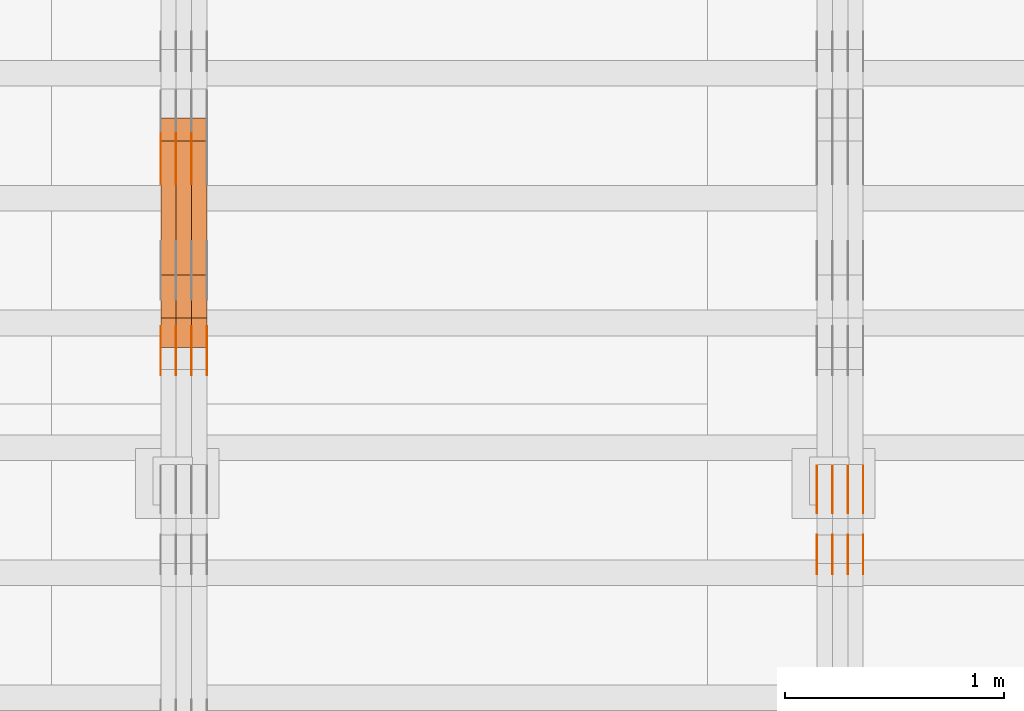
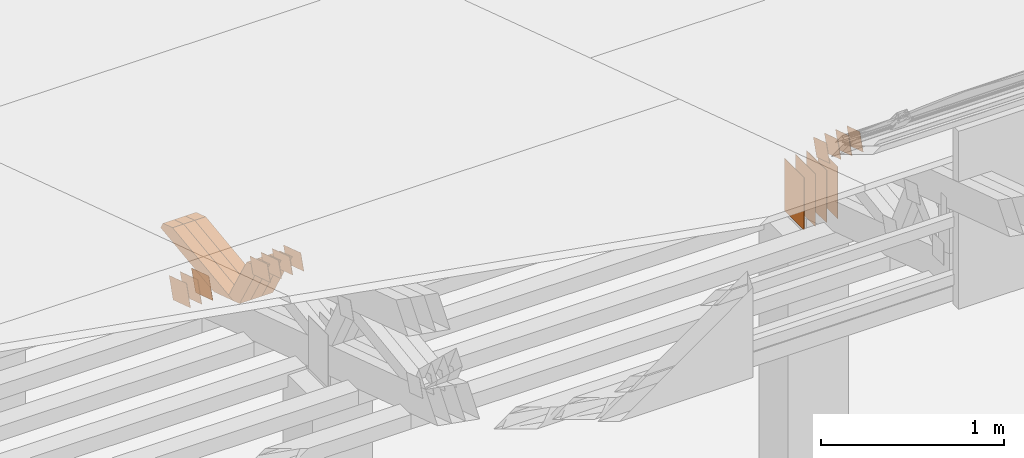
# One storey, part 292 of 385: 29 proxies.
"""IFC2X3 building model written with IfcOpenShell, lengths in millimetres."""

from ifc_helpers import new_model, entity, si_unit, converted_unit, derived_unit, direction, frame, origin, origin_2d_with_axis, place, context, subcontext, project, spatial, polyline, rectangle, outline, extrude, source, transform, mapped, material, type_object, type_shapes, element, save


model = new_model("IFC2X3")

# Units and contexts
model_context = context("Model", 3, precision=0.01, world=origin(), true_north=direction((6.12303176911189e-17, 1.0)))
body_context = subcontext(model_context, "Body", "Model", "MODEL_VIEW")
ifc_project = project(units=[si_unit("LENGTHUNIT", "METRE", prefix="MILLI"), si_unit("AREAUNIT", "SQUARE_METRE"), si_unit("VOLUMEUNIT", "CUBIC_METRE"), converted_unit("PLANEANGLEUNIT", "DEGREE", entity("IfcRatioMeasure", 0.0174532925199433), si_unit("PLANEANGLEUNIT", "RADIAN"), dimensions=[0, 0, 0, 0, 0, 0, 0]), si_unit("MASSUNIT", "GRAM", prefix="KILO"), derived_unit("MASSDENSITYUNIT", [(si_unit("MASSUNIT", "GRAM", prefix="KILO"), 1), (si_unit("LENGTHUNIT", "METRE"), -3)]), si_unit("TIMEUNIT", "SECOND"), si_unit("FREQUENCYUNIT", "HERTZ"), si_unit("THERMODYNAMICTEMPERATUREUNIT", "DEGREE_CELSIUS"), derived_unit("THERMALTRANSMITTANCEUNIT", [(si_unit("MASSUNIT", "GRAM", prefix="KILO"), 1), (si_unit("THERMODYNAMICTEMPERATUREUNIT", "KELVIN"), -1), (si_unit("TIMEUNIT", "SECOND"), -3)]), derived_unit("VOLUMETRICFLOWRATEUNIT", [(si_unit("LENGTHUNIT", "METRE"), 3), (si_unit("TIMEUNIT", "SECOND"), -1)]), si_unit("ELECTRICCURRENTUNIT", "AMPERE"), si_unit("ELECTRICVOLTAGEUNIT", "VOLT"), si_unit("POWERUNIT", "WATT"), si_unit("FORCEUNIT", "NEWTON", prefix="KILO"), si_unit("ILLUMINANCEUNIT", "LUX"), si_unit("LUMINOUSFLUXUNIT", "LUMEN"), si_unit("LUMINOUSINTENSITYUNIT", "CANDELA"), derived_unit("USERDEFINED", [(si_unit("MASSUNIT", "GRAM", prefix="KILO"), -1), (si_unit("LENGTHUNIT", "METRE"), -2), (si_unit("TIMEUNIT", "SECOND"), 3), (si_unit("LUMINOUSFLUXUNIT", "LUMEN"), 1)]), derived_unit("LINEARVELOCITYUNIT", [(si_unit("LENGTHUNIT", "METRE"), 1), (si_unit("TIMEUNIT", "SECOND"), -1)]), si_unit("PRESSUREUNIT", "PASCAL"), derived_unit("USERDEFINED", [(si_unit("LENGTHUNIT", "METRE"), -2), (si_unit("MASSUNIT", "GRAM", prefix="KILO"), 1), (si_unit("TIMEUNIT", "SECOND"), -2)])], contexts=[model_context])

# Site, building, storey
site_placement = place(None, origin())
site = spatial("IfcSite", under=ifc_project, at=site_placement, CompositionType="ELEMENT")
building_placement = place(site_placement, origin())
building = spatial("IfcBuilding", under=site, at=building_placement, CompositionType="ELEMENT")
storey_placement = place(building_placement, origin())
storey = spatial("IfcBuildingStorey", under=building, at=storey_placement, Name="Default", CompositionType="ELEMENT", Elevation=0.0)

# Proxies
ifc_material_1 = material(Name="IfcSurfaceStyle #478098")
building_element_proxy_type_1 = type_object("IfcBuildingElementProxyType", PredefinedType="NOTDEFINED", material=ifc_material_1)
shared_shape_1 = source(origin(), body_context, "Body", "SweptSolid", [
    extrude(rectangle(XDim=350.0, YDim=215.999999999984, at=origin_2d_with_axis()), frame((175.0, 108.0, 0.0), z_axis=(0.0, 0.0, 1.0), x_axis=(-1.0, 0.0, 0.0)), (0.0, 0.0, 1.0), 1.29999999999999),
])
type_shapes(building_element_proxy_type_1, [shared_shape_1])
proxy_1_placement = place(building_placement, frame((39386.3, 17459.2939453125, 3165.36425781251), z_axis=(-1.0, 0.0, 0.0), x_axis=(0.0, 0.0, -1.0)))
element("IfcBuildingElementProxy", 1, at=proxy_1_placement, inside=storey, type_object=building_element_proxy_type_1, material=ifc_material_1, context=body_context, shape_type="MappedRepresentation", body=[
    mapped(shared_shape_1, transform((0.0, 0.0, 0.0), scale=1.0)),
])
ifc_material_2 = material(Name="IfcSurfaceStyle #478041")
building_element_proxy_type_2 = type_object("IfcBuildingElementProxyType", PredefinedType="NOTDEFINED", material=ifc_material_2)
shared_shape_2 = source(origin(), body_context, "Body", "SweptSolid", [
    extrude(rectangle(XDim=350.0, YDim=215.999999999984, at=origin_2d_with_axis()), frame((175.0, 108.0, 0.0), z_axis=(0.0, 0.0, 1.0), x_axis=(-1.0, 0.0, 0.0)), (0.0, 0.0, 1.0), 1.29999999999999),
])
type_shapes(building_element_proxy_type_2, [shared_shape_2])
proxy_2_placement = place(building_placement, frame((39315.0, 17459.2939453125, 3165.36425781251), z_axis=(-1.0, 0.0, 0.0), x_axis=(0.0, 0.0, -1.0)))
element("IfcBuildingElementProxy", 2, at=proxy_2_placement, inside=storey, type_object=building_element_proxy_type_2, material=ifc_material_2, context=body_context, shape_type="MappedRepresentation", body=[
    mapped(shared_shape_2, transform((0.0, 0.0, 0.0), scale=1.0)),
])
ifc_material_3 = material(Name="IfcSurfaceStyle #477984")
building_element_proxy_type_3 = type_object("IfcBuildingElementProxyType", PredefinedType="NOTDEFINED", material=ifc_material_3)
shared_shape_3 = source(origin(), body_context, "Body", "SweptSolid", [
    extrude(rectangle(XDim=350.0, YDim=215.999999999984, at=origin_2d_with_axis()), frame((175.0, 108.0, 0.0), z_axis=(0.0, 0.0, 1.0), x_axis=(-1.0, 0.0, 0.0)), (0.0, 0.0, 1.0), 1.29999999999999),
])
type_shapes(building_element_proxy_type_3, [shared_shape_3])
proxy_3_placement = place(building_placement, frame((39316.3, 17459.2939453125, 3165.36425781251), z_axis=(-1.0, 0.0, 0.0), x_axis=(0.0, 0.0, -1.0)))
element("IfcBuildingElementProxy", 3, at=proxy_3_placement, inside=storey, type_object=building_element_proxy_type_3, material=ifc_material_3, context=body_context, shape_type="MappedRepresentation", body=[
    mapped(shared_shape_3, transform((0.0, 0.0, 0.0), scale=1.0)),
])
ifc_material_4 = material(Name="IfcSurfaceStyle #477927")
building_element_proxy_type_4 = type_object("IfcBuildingElementProxyType", PredefinedType="NOTDEFINED", material=ifc_material_4)
shared_shape_4 = source(origin(), body_context, "Body", "SweptSolid", [
    extrude(rectangle(XDim=350.0, YDim=215.999999999984, at=origin_2d_with_axis()), frame((175.0, 108.0, 0.0), z_axis=(0.0, 0.0, 1.0), x_axis=(-1.0, 0.0, 0.0)), (0.0, 0.0, 1.0), 1.29999999999998),
])
type_shapes(building_element_proxy_type_4, [shared_shape_4])
proxy_4_placement = place(building_placement, frame((39245.0, 17459.2939453125, 3165.36425781251), z_axis=(-1.0, 0.0, 0.0), x_axis=(0.0, 0.0, -1.0)))
element("IfcBuildingElementProxy", 4, at=proxy_4_placement, inside=storey, type_object=building_element_proxy_type_4, material=ifc_material_4, context=body_context, shape_type="MappedRepresentation", body=[
    mapped(shared_shape_4, transform((0.0, 0.0, 0.0), scale=1.0)),
])
ifc_material_5 = material(Name="IfcSurfaceStyle #477870")
building_element_proxy_type_5 = type_object("IfcBuildingElementProxyType", PredefinedType="NOTDEFINED", material=ifc_material_5)
shared_shape_5 = source(origin(), body_context, "Body", "SweptSolid", [
    extrude(rectangle(XDim=350.0, YDim=215.999999999984, at=origin_2d_with_axis()), frame((175.0, 108.0, 0.0), z_axis=(0.0, 0.0, 1.0), x_axis=(-1.0, 0.0, 0.0)), (0.0, 0.0, 1.0), 1.29999999999998),
])
type_shapes(building_element_proxy_type_5, [shared_shape_5])
proxy_5_placement = place(building_placement, frame((39246.3, 17459.2939453125, 3165.36425781251), z_axis=(-1.0, 0.0, 0.0), x_axis=(0.0, 0.0, -1.0)))
element("IfcBuildingElementProxy", 5, at=proxy_5_placement, inside=storey, type_object=building_element_proxy_type_5, material=ifc_material_5, context=body_context, shape_type="MappedRepresentation", body=[
    mapped(shared_shape_5, transform((0.0, 0.0, 0.0), scale=1.0)),
])
ifc_material_6 = material(Name="IfcSurfaceStyle #477813")
building_element_proxy_type_6 = type_object("IfcBuildingElementProxyType", PredefinedType="NOTDEFINED", material=ifc_material_6)
shared_shape_6 = source(origin(), body_context, "Body", "SweptSolid", [
    extrude(rectangle(XDim=350.0, YDim=215.999999999984, at=origin_2d_with_axis()), frame((175.0, 108.0, 0.0), z_axis=(0.0, 0.0, 1.0), x_axis=(-1.0, 0.0, 0.0)), (0.0, 0.0, 1.0), 1.29999999999998),
])
type_shapes(building_element_proxy_type_6, [shared_shape_6])
proxy_6_placement = place(building_placement, frame((39175.0, 17459.2939453125, 3165.36425781251), z_axis=(-1.0, 0.0, 0.0), x_axis=(0.0, 0.0, -1.0)))
element("IfcBuildingElementProxy", 6, at=proxy_6_placement, inside=storey, type_object=building_element_proxy_type_6, material=ifc_material_6, context=body_context, shape_type="MappedRepresentation", body=[
    mapped(shared_shape_6, transform((0.0, 0.0, 0.0), scale=1.0)),
])
ifc_material_7 = material(Name="IfcSurfaceStyle #474678")
building_element_proxy_type_7 = type_object("IfcBuildingElementProxyType", PredefinedType="NOTDEFINED", material=ifc_material_7)
shared_shape_7 = source(origin(), body_context, "Body", "SweptSolid", [
    extrude(outline(polyline([(-74.9998605591058, -59.9999264677524), (74.999875428623, -59.9999264677524), (74.9998605591068, 59.9999264677524), (-74.9998754286239, 59.9999264677524), (-74.9998605591058, -59.9999264677524)])), frame((75.0002460484325, 60.0000016373508, 0.0), z_axis=(0.0, 0.0, 1.0), x_axis=(-1.0, 0.0, 0.0)), (0.0, 0.0, 1.0), 1.3),
])
type_shapes(building_element_proxy_type_7, [shared_shape_7])
proxy_7_placement = place(building_placement, frame((39386.3, 17107.0599369346, 3383.82825001787), z_axis=(-1.0, 0.0, 0.0), x_axis=(0.0, -0.951056516295154, 0.309016994374948)))
element("IfcBuildingElementProxy", 7, at=proxy_7_placement, inside=storey, type_object=building_element_proxy_type_7, material=ifc_material_7, context=body_context, shape_type="MappedRepresentation", body=[
    mapped(shared_shape_7, transform((0.0, 0.0, 0.0), scale=1.0)),
])
ifc_material_8 = material(Name="IfcSurfaceStyle #474621")
building_element_proxy_type_8 = type_object("IfcBuildingElementProxyType", PredefinedType="NOTDEFINED", material=ifc_material_8)
shared_shape_8 = source(origin(), body_context, "Body", "SweptSolid", [
    extrude(outline(polyline([(-74.9998605591058, -59.9999264677524), (74.999875428623, -59.9999264677524), (74.9998605591068, 59.9999264677524), (-74.9998754286239, 59.9999264677524), (-74.9998605591058, -59.9999264677524)])), frame((75.0002460484325, 60.0000016373508, 0.0), z_axis=(0.0, 0.0, 1.0), x_axis=(-1.0, 0.0, 0.0)), (0.0, 0.0, 1.0), 1.3),
])
type_shapes(building_element_proxy_type_8, [shared_shape_8])
proxy_8_placement = place(building_placement, frame((39315.0, 17107.0599369346, 3383.82825001787), z_axis=(-1.0, 0.0, 0.0), x_axis=(0.0, -0.951056516295154, 0.309016994374948)))
element("IfcBuildingElementProxy", 8, at=proxy_8_placement, inside=storey, type_object=building_element_proxy_type_8, material=ifc_material_8, context=body_context, shape_type="MappedRepresentation", body=[
    mapped(shared_shape_8, transform((0.0, 0.0, 0.0), scale=1.0)),
])
ifc_material_9 = material(Name="IfcSurfaceStyle #474564")
building_element_proxy_type_9 = type_object("IfcBuildingElementProxyType", PredefinedType="NOTDEFINED", material=ifc_material_9)
shared_shape_9 = source(origin(), body_context, "Body", "SweptSolid", [
    extrude(outline(polyline([(-74.9998605591058, -59.9999264677524), (74.999875428623, -59.9999264677524), (74.9998605591068, 59.9999264677524), (-74.9998754286239, 59.9999264677524), (-74.9998605591058, -59.9999264677524)])), frame((75.0002460484325, 60.0000016373508, 0.0), z_axis=(0.0, 0.0, 1.0), x_axis=(-1.0, 0.0, 0.0)), (0.0, 0.0, 1.0), 1.3),
])
type_shapes(building_element_proxy_type_9, [shared_shape_9])
proxy_9_placement = place(building_placement, frame((39316.3, 17107.0599369346, 3383.82825001787), z_axis=(-1.0, 0.0, 0.0), x_axis=(0.0, -0.951056516295154, 0.309016994374948)))
element("IfcBuildingElementProxy", 9, at=proxy_9_placement, inside=storey, type_object=building_element_proxy_type_9, material=ifc_material_9, context=body_context, shape_type="MappedRepresentation", body=[
    mapped(shared_shape_9, transform((0.0, 0.0, 0.0), scale=1.0)),
])
ifc_material_10 = material(Name="IfcSurfaceStyle #474507")
building_element_proxy_type_10 = type_object("IfcBuildingElementProxyType", PredefinedType="NOTDEFINED", material=ifc_material_10)
shared_shape_10 = source(origin(), body_context, "Body", "SweptSolid", [
    extrude(outline(polyline([(-74.9998605591058, -59.9999264677524), (74.999875428623, -59.9999264677524), (74.9998605591068, 59.9999264677524), (-74.9998754286239, 59.9999264677524), (-74.9998605591058, -59.9999264677524)])), frame((75.0002460484325, 60.0000016373508, 0.0), z_axis=(0.0, 0.0, 1.0), x_axis=(-1.0, 0.0, 0.0)), (0.0, 0.0, 1.0), 1.29999999999999),
])
type_shapes(building_element_proxy_type_10, [shared_shape_10])
proxy_10_placement = place(building_placement, frame((39245.0, 17107.0599369346, 3383.82825001787), z_axis=(-1.0, 0.0, 0.0), x_axis=(0.0, -0.951056516295154, 0.309016994374948)))
element("IfcBuildingElementProxy", 10, at=proxy_10_placement, inside=storey, type_object=building_element_proxy_type_10, material=ifc_material_10, context=body_context, shape_type="MappedRepresentation", body=[
    mapped(shared_shape_10, transform((0.0, 0.0, 0.0), scale=1.0)),
])
ifc_material_11 = material(Name="IfcSurfaceStyle #474450")
building_element_proxy_type_11 = type_object("IfcBuildingElementProxyType", PredefinedType="NOTDEFINED", material=ifc_material_11)
shared_shape_11 = source(origin(), body_context, "Body", "SweptSolid", [
    extrude(outline(polyline([(-74.9998605591058, -59.9999264677524), (74.999875428623, -59.9999264677524), (74.9998605591068, 59.9999264677524), (-74.9998754286239, 59.9999264677524), (-74.9998605591058, -59.9999264677524)])), frame((75.0002460484325, 60.0000016373508, 0.0), z_axis=(0.0, 0.0, 1.0), x_axis=(-1.0, 0.0, 0.0)), (0.0, 0.0, 1.0), 1.29999999999999),
])
type_shapes(building_element_proxy_type_11, [shared_shape_11])
proxy_11_placement = place(building_placement, frame((39246.3, 17107.0599369346, 3383.82825001787), z_axis=(-1.0, 0.0, 0.0), x_axis=(0.0, -0.951056516295154, 0.309016994374948)))
element("IfcBuildingElementProxy", 11, at=proxy_11_placement, inside=storey, type_object=building_element_proxy_type_11, material=ifc_material_11, context=body_context, shape_type="MappedRepresentation", body=[
    mapped(shared_shape_11, transform((0.0, 0.0, 0.0), scale=1.0)),
])
ifc_material_12 = material(Name="IfcSurfaceStyle #474393")
building_element_proxy_type_12 = type_object("IfcBuildingElementProxyType", PredefinedType="NOTDEFINED", material=ifc_material_12)
shared_shape_12 = source(origin(), body_context, "Body", "SweptSolid", [
    extrude(outline(polyline([(-74.9998605591058, -59.9999264677524), (74.999875428623, -59.9999264677524), (74.9998605591068, 59.9999264677524), (-74.9998754286239, 59.9999264677524), (-74.9998605591058, -59.9999264677524)])), frame((75.0002460484325, 60.0000016373508, 0.0), z_axis=(0.0, 0.0, 1.0), x_axis=(-1.0, 0.0, 0.0)), (0.0, 0.0, 1.0), 1.29999999999999),
])
type_shapes(building_element_proxy_type_12, [shared_shape_12])
proxy_12_placement = place(building_placement, frame((39175.0, 17107.0599369346, 3383.82825001787), z_axis=(-1.0, 0.0, 0.0), x_axis=(0.0, -0.951056516295154, 0.309016994374948)))
element("IfcBuildingElementProxy", 12, at=proxy_12_placement, inside=storey, type_object=building_element_proxy_type_12, material=ifc_material_12, context=body_context, shape_type="MappedRepresentation", body=[
    mapped(shared_shape_12, transform((0.0, 0.0, 0.0), scale=1.0)),
])
ifc_material_13 = material(Name="IfcSurfaceStyle #443951")
building_element_proxy_type_13 = type_object("IfcBuildingElementProxyType", PredefinedType="NOTDEFINED", material=ifc_material_13)
shared_shape_13 = source(origin(), body_context, "Body", "SweptSolid", [
    extrude(outline(polyline([(-99.999796294464, -72.0000050220467), (99.9998768370438, -72.0000050220467), (100.000260677528, 72.0000050220467), (-100.000341220108, 72.0000050220467), (-99.999796294464, -72.0000050220467)])), frame((100.000260677528, 72.0000050220467, 0.0), z_axis=(0.0, 0.0, 1.0), x_axis=(-1.0, 0.0, 0.0)), (0.0, 0.0, 1.0), 1.3),
])
type_shapes(building_element_proxy_type_13, [shared_shape_13])
proxy_13_placement = place(building_placement, frame((36315.0, 18936.3876569477, 2373.90613192527), z_axis=(-1.0, 0.0, 0.0), x_axis=(0.0, -0.951056516295124, 0.309016994375039)))
element("IfcBuildingElementProxy", 13, at=proxy_13_placement, inside=storey, type_object=building_element_proxy_type_13, material=ifc_material_13, context=body_context, shape_type="MappedRepresentation", body=[
    mapped(shared_shape_13, transform((0.0, 0.0, 0.0), scale=1.0)),
])
ifc_material_14 = material(Name="IfcSurfaceStyle #443894")
building_element_proxy_type_14 = type_object("IfcBuildingElementProxyType", PredefinedType="NOTDEFINED", material=ifc_material_14)
shared_shape_14 = source(origin(), body_context, "Body", "SweptSolid", [
    extrude(outline(polyline([(-99.999796294464, -72.0000050220467), (99.9998768370438, -72.0000050220467), (100.000260677528, 72.0000050220467), (-100.000341220108, 72.0000050220467), (-99.999796294464, -72.0000050220467)])), frame((100.000260677528, 72.0000050220467, 0.0), z_axis=(0.0, 0.0, 1.0), x_axis=(-1.0, 0.0, 0.0)), (0.0, 0.0, 1.0), 1.3),
])
type_shapes(building_element_proxy_type_14, [shared_shape_14])
proxy_14_placement = place(building_placement, frame((36316.3, 18936.3876569477, 2373.90613192527), z_axis=(-1.0, 0.0, 0.0), x_axis=(0.0, -0.951056516295124, 0.309016994375039)))
element("IfcBuildingElementProxy", 14, at=proxy_14_placement, inside=storey, type_object=building_element_proxy_type_14, material=ifc_material_14, context=body_context, shape_type="MappedRepresentation", body=[
    mapped(shared_shape_14, transform((0.0, 0.0, 0.0), scale=1.0)),
])
ifc_material_15 = material(Name="IfcSurfaceStyle #443837")
building_element_proxy_type_15 = type_object("IfcBuildingElementProxyType", PredefinedType="NOTDEFINED", material=ifc_material_15)
shared_shape_15 = source(origin(), body_context, "Body", "SweptSolid", [
    extrude(outline(polyline([(-99.999796294464, -72.0000050220467), (99.9998768370438, -72.0000050220467), (100.000260677528, 72.0000050220467), (-100.000341220108, 72.0000050220467), (-99.999796294464, -72.0000050220467)])), frame((100.000260677528, 72.0000050220467, 0.0), z_axis=(0.0, 0.0, 1.0), x_axis=(-1.0, 0.0, 0.0)), (0.0, 0.0, 1.0), 1.29999999999998),
])
type_shapes(building_element_proxy_type_15, [shared_shape_15])
proxy_15_placement = place(building_placement, frame((36245.0, 18936.3876569477, 2373.90613192527), z_axis=(-1.0, 0.0, 0.0), x_axis=(0.0, -0.951056516295124, 0.309016994375039)))
element("IfcBuildingElementProxy", 15, at=proxy_15_placement, inside=storey, type_object=building_element_proxy_type_15, material=ifc_material_15, context=body_context, shape_type="MappedRepresentation", body=[
    mapped(shared_shape_15, transform((0.0, 0.0, 0.0), scale=1.0)),
])
ifc_material_16 = material(Name="IfcSurfaceStyle #443780")
building_element_proxy_type_16 = type_object("IfcBuildingElementProxyType", PredefinedType="NOTDEFINED", material=ifc_material_16)
shared_shape_16 = source(origin(), body_context, "Body", "SweptSolid", [
    extrude(outline(polyline([(-99.999796294464, -72.0000050220467), (99.9998768370438, -72.0000050220467), (100.000260677528, 72.0000050220467), (-100.000341220108, 72.0000050220467), (-99.999796294464, -72.0000050220467)])), frame((100.000260677528, 72.0000050220467, 0.0), z_axis=(0.0, 0.0, 1.0), x_axis=(-1.0, 0.0, 0.0)), (0.0, 0.0, 1.0), 1.29999999999998),
])
type_shapes(building_element_proxy_type_16, [shared_shape_16])
proxy_16_placement = place(building_placement, frame((36246.3, 18936.3876569477, 2373.90613192527), z_axis=(-1.0, 0.0, 0.0), x_axis=(0.0, -0.951056516295124, 0.309016994375039)))
element("IfcBuildingElementProxy", 16, at=proxy_16_placement, inside=storey, type_object=building_element_proxy_type_16, material=ifc_material_16, context=body_context, shape_type="MappedRepresentation", body=[
    mapped(shared_shape_16, transform((0.0, 0.0, 0.0), scale=1.0)),
])
ifc_material_17 = material(Name="IfcSurfaceStyle #443723")
building_element_proxy_type_17 = type_object("IfcBuildingElementProxyType", PredefinedType="NOTDEFINED", material=ifc_material_17)
shared_shape_17 = source(origin(), body_context, "Body", "SweptSolid", [
    extrude(outline(polyline([(-99.999796294464, -72.0000050220467), (99.9998768370438, -72.0000050220467), (100.000260677528, 72.0000050220467), (-100.000341220108, 72.0000050220467), (-99.999796294464, -72.0000050220467)])), frame((100.000260677528, 72.0000050220467, 0.0), z_axis=(0.0, 0.0, 1.0), x_axis=(-1.0, 0.0, 0.0)), (0.0, 0.0, 1.0), 1.29999999999999),
])
type_shapes(building_element_proxy_type_17, [shared_shape_17])
proxy_17_placement = place(building_placement, frame((36175.0, 18936.3876569477, 2373.90613192527), z_axis=(-1.0, 0.0, 0.0), x_axis=(0.0, -0.951056516295124, 0.309016994375039)))
element("IfcBuildingElementProxy", 17, at=proxy_17_placement, inside=storey, type_object=building_element_proxy_type_17, material=ifc_material_17, context=body_context, shape_type="MappedRepresentation", body=[
    mapped(shared_shape_17, transform((0.0, 0.0, 0.0), scale=1.0)),
])
ifc_material_18 = material(Name="IfcSurfaceStyle #439562")
building_element_proxy_type_18 = type_object("IfcBuildingElementProxyType", PredefinedType="NOTDEFINED", material=ifc_material_18)
shared_shape_18 = source(origin(), body_context, "Body", "SweptSolid", [
    extrude(outline(polyline([(-99.9999427841299, -54.0000599375792), (99.9996549037756, -54.0000599375792), (100.000407167194, 54.0000599375792), (-100.00011928684, 54.0000599375792), (-99.9999427841299, -54.0000599375792)])), frame((100.000407167194, 54.0000599375792, 0.0), z_axis=(0.0, 0.0, 1.0), x_axis=(-1.0, 0.0, 0.0)), (0.0, 0.0, 1.0), 1.3),
])
type_shapes(building_element_proxy_type_18, [shared_shape_18])
proxy_18_placement = place(building_placement, frame((36386.3, 18065.0682492591, 3072.55239547302), z_axis=(-1.0, 0.0, 0.0), x_axis=(0.0, -0.951056516295154, 0.309016994374948)))
element("IfcBuildingElementProxy", 18, at=proxy_18_placement, inside=storey, type_object=building_element_proxy_type_18, material=ifc_material_18, context=body_context, shape_type="MappedRepresentation", body=[
    mapped(shared_shape_18, transform((0.0, 0.0, 0.0), scale=1.0)),
])
ifc_material_19 = material(Name="IfcSurfaceStyle #439505")
building_element_proxy_type_19 = type_object("IfcBuildingElementProxyType", PredefinedType="NOTDEFINED", material=ifc_material_19)
shared_shape_19 = source(origin(), body_context, "Body", "SweptSolid", [
    extrude(outline(polyline([(-99.9999427841299, -54.0000599375792), (99.9996549037756, -54.0000599375792), (100.000407167194, 54.0000599375792), (-100.00011928684, 54.0000599375792), (-99.9999427841299, -54.0000599375792)])), frame((100.000407167194, 54.0000599375792, 0.0), z_axis=(0.0, 0.0, 1.0), x_axis=(-1.0, 0.0, 0.0)), (0.0, 0.0, 1.0), 1.3),
])
type_shapes(building_element_proxy_type_19, [shared_shape_19])
proxy_19_placement = place(building_placement, frame((36315.0, 18065.0682492591, 3072.55239547302), z_axis=(-1.0, 0.0, 0.0), x_axis=(0.0, -0.951056516295154, 0.309016994374948)))
element("IfcBuildingElementProxy", 19, at=proxy_19_placement, inside=storey, type_object=building_element_proxy_type_19, material=ifc_material_19, context=body_context, shape_type="MappedRepresentation", body=[
    mapped(shared_shape_19, transform((0.0, 0.0, 0.0), scale=1.0)),
])
ifc_material_20 = material(Name="IfcSurfaceStyle #439448")
building_element_proxy_type_20 = type_object("IfcBuildingElementProxyType", PredefinedType="NOTDEFINED", material=ifc_material_20)
shared_shape_20 = source(origin(), body_context, "Body", "SweptSolid", [
    extrude(outline(polyline([(-99.9999427841299, -54.0000599375792), (99.9996549037756, -54.0000599375792), (100.000407167194, 54.0000599375792), (-100.00011928684, 54.0000599375792), (-99.9999427841299, -54.0000599375792)])), frame((100.000407167194, 54.0000599375792, 0.0), z_axis=(0.0, 0.0, 1.0), x_axis=(-1.0, 0.0, 0.0)), (0.0, 0.0, 1.0), 1.3),
])
type_shapes(building_element_proxy_type_20, [shared_shape_20])
proxy_20_placement = place(building_placement, frame((36316.3, 18065.0682492591, 3072.55239547302), z_axis=(-1.0, 0.0, 0.0), x_axis=(0.0, -0.951056516295154, 0.309016994374948)))
element("IfcBuildingElementProxy", 20, at=proxy_20_placement, inside=storey, type_object=building_element_proxy_type_20, material=ifc_material_20, context=body_context, shape_type="MappedRepresentation", body=[
    mapped(shared_shape_20, transform((0.0, 0.0, 0.0), scale=1.0)),
])
ifc_material_21 = material(Name="IfcSurfaceStyle #439391")
building_element_proxy_type_21 = type_object("IfcBuildingElementProxyType", PredefinedType="NOTDEFINED", material=ifc_material_21)
shared_shape_21 = source(origin(), body_context, "Body", "SweptSolid", [
    extrude(outline(polyline([(-99.9999427841299, -54.0000599375792), (99.9996549037756, -54.0000599375792), (100.000407167194, 54.0000599375792), (-100.00011928684, 54.0000599375792), (-99.9999427841299, -54.0000599375792)])), frame((100.000407167194, 54.0000599375792, 0.0), z_axis=(0.0, 0.0, 1.0), x_axis=(-1.0, 0.0, 0.0)), (0.0, 0.0, 1.0), 1.29999999999998),
])
type_shapes(building_element_proxy_type_21, [shared_shape_21])
proxy_21_placement = place(building_placement, frame((36245.0, 18065.0682492591, 3072.55239547302), z_axis=(-1.0, 0.0, 0.0), x_axis=(0.0, -0.951056516295154, 0.309016994374948)))
element("IfcBuildingElementProxy", 21, at=proxy_21_placement, inside=storey, type_object=building_element_proxy_type_21, material=ifc_material_21, context=body_context, shape_type="MappedRepresentation", body=[
    mapped(shared_shape_21, transform((0.0, 0.0, 0.0), scale=1.0)),
])
ifc_material_22 = material(Name="IfcSurfaceStyle #439334")
building_element_proxy_type_22 = type_object("IfcBuildingElementProxyType", PredefinedType="NOTDEFINED", material=ifc_material_22)
shared_shape_22 = source(origin(), body_context, "Body", "SweptSolid", [
    extrude(outline(polyline([(-99.9999427841299, -54.0000599375792), (99.9996549037756, -54.0000599375792), (100.000407167194, 54.0000599375792), (-100.00011928684, 54.0000599375792), (-99.9999427841299, -54.0000599375792)])), frame((100.000407167194, 54.0000599375792, 0.0), z_axis=(0.0, 0.0, 1.0), x_axis=(-1.0, 0.0, 0.0)), (0.0, 0.0, 1.0), 1.29999999999998),
])
type_shapes(building_element_proxy_type_22, [shared_shape_22])
proxy_22_placement = place(building_placement, frame((36246.3, 18065.0682492591, 3072.55239547302), z_axis=(-1.0, 0.0, 0.0), x_axis=(0.0, -0.951056516295154, 0.309016994374948)))
element("IfcBuildingElementProxy", 22, at=proxy_22_placement, inside=storey, type_object=building_element_proxy_type_22, material=ifc_material_22, context=body_context, shape_type="MappedRepresentation", body=[
    mapped(shared_shape_22, transform((0.0, 0.0, 0.0), scale=1.0)),
])
ifc_material_23 = material(Name="IfcSurfaceStyle #439277")
building_element_proxy_type_23 = type_object("IfcBuildingElementProxyType", PredefinedType="NOTDEFINED", material=ifc_material_23)
shared_shape_23 = source(origin(), body_context, "Body", "SweptSolid", [
    extrude(outline(polyline([(-99.9999427841299, -54.0000599375792), (99.9996549037756, -54.0000599375792), (100.000407167194, 54.0000599375792), (-100.00011928684, 54.0000599375792), (-99.9999427841299, -54.0000599375792)])), frame((100.000407167194, 54.0000599375792, 0.0), z_axis=(0.0, 0.0, 1.0), x_axis=(-1.0, 0.0, 0.0)), (0.0, 0.0, 1.0), 1.29999999999999),
])
type_shapes(building_element_proxy_type_23, [shared_shape_23])
proxy_23_placement = place(building_placement, frame((36175.0, 18065.0682492591, 3072.55239547302), z_axis=(-1.0, 0.0, 0.0), x_axis=(0.0, -0.951056516295154, 0.309016994374948)))
element("IfcBuildingElementProxy", 23, at=proxy_23_placement, inside=storey, type_object=building_element_proxy_type_23, material=ifc_material_23, context=body_context, shape_type="MappedRepresentation", body=[
    mapped(shared_shape_23, transform((0.0, 0.0, 0.0), scale=1.0)),
])
ifc_material_24 = material(Name="IfcSurfaceStyle #429410")
building_element_proxy_type_24 = type_object("IfcBuildingElementProxyType", Name="T1-W35 429408", PredefinedType="NOTDEFINED", material=ifc_material_24)
shared_shape_24 = source(origin(), body_context, "Body", "SweptSolid", [
    extrude(outline(polyline([(-196.877231354918, -47.499850828051), (197.289756738813, -47.499850828051), (177.380838136073, -0.000131002767018074), (124.615181369032, 47.4999163294346), (-302.408544889, 47.4999163294346), (-196.877231354918, -47.499850828051)])), frame((197.289756738813, 47.5002438363521, 0.0), z_axis=(0.0, 0.0, 1.0), x_axis=(-1.0, 0.0, 0.0)), (0.0, 0.0, 1.0), 70.0),
])
type_shapes(building_element_proxy_type_24, [shared_shape_24])
proxy_24_placement = place(building_placement, frame((36385.0, 18249.5528960018, 2724.16980022534), z_axis=(-1.0, 0.0, 0.0), x_axis=(0.0, -0.5, 0.866025403784439)))
element("IfcBuildingElementProxy", 24, at=proxy_24_placement, inside=storey, type_object=building_element_proxy_type_24, material=ifc_material_24, Name="T1-W35", context=body_context, shape_type="MappedRepresentation", body=[
    mapped(shared_shape_24, transform((0.0, 0.0, 0.0), scale=1.0)),
])
ifc_material_25 = material(Name="IfcSurfaceStyle #429344")
building_element_proxy_type_25 = type_object("IfcBuildingElementProxyType", Name="T1-W35 429342", PredefinedType="NOTDEFINED", material=ifc_material_25)
shared_shape_25 = source(origin(), body_context, "Body", "SweptSolid", [
    extrude(outline(polyline([(-196.877231354918, -47.499850828051), (197.289756738813, -47.499850828051), (177.380838136073, -0.000131002767018074), (124.615181369032, 47.4999163294346), (-302.408544889, 47.4999163294346), (-196.877231354918, -47.499850828051)])), frame((197.289756738813, 47.5002438363521, 0.0), z_axis=(0.0, 0.0, 1.0), x_axis=(-1.0, 0.0, 0.0)), (0.0, 0.0, 1.0), 70.0),
])
type_shapes(building_element_proxy_type_25, [shared_shape_25])
proxy_25_placement = place(building_placement, frame((36315.0, 18249.5528960018, 2724.16980022534), z_axis=(-1.0, 0.0, 0.0), x_axis=(0.0, -0.5, 0.866025403784439)))
element("IfcBuildingElementProxy", 25, at=proxy_25_placement, inside=storey, type_object=building_element_proxy_type_25, material=ifc_material_25, Name="T1-W35", context=body_context, shape_type="MappedRepresentation", body=[
    mapped(shared_shape_25, transform((0.0, 0.0, 0.0), scale=1.0)),
])
ifc_material_26 = material(Name="IfcSurfaceStyle #429278")
building_element_proxy_type_26 = type_object("IfcBuildingElementProxyType", Name="T1-W35 429276", PredefinedType="NOTDEFINED", material=ifc_material_26)
shared_shape_26 = source(origin(), body_context, "Body", "SweptSolid", [
    extrude(outline(polyline([(-196.877231354918, -47.499850828051), (197.289756738813, -47.499850828051), (177.380838136073, -0.000131002767018074), (124.615181369032, 47.4999163294346), (-302.408544889, 47.4999163294346), (-196.877231354918, -47.499850828051)])), frame((197.289756738813, 47.5002438363521, 0.0), z_axis=(0.0, 0.0, 1.0), x_axis=(-1.0, 0.0, 0.0)), (0.0, 0.0, 1.0), 70.0),
])
type_shapes(building_element_proxy_type_26, [shared_shape_26])
proxy_26_placement = place(building_placement, frame((36245.0, 18249.5528960018, 2724.16980022534), z_axis=(-1.0, 0.0, 0.0), x_axis=(0.0, -0.5, 0.866025403784439)))
element("IfcBuildingElementProxy", 26, at=proxy_26_placement, inside=storey, type_object=building_element_proxy_type_26, material=ifc_material_26, Name="T1-W35", context=body_context, shape_type="MappedRepresentation", body=[
    mapped(shared_shape_26, transform((0.0, 0.0, 0.0), scale=1.0)),
])
ifc_material_27 = material(Name="IfcSurfaceStyle #429014")
building_element_proxy_type_27 = type_object("IfcBuildingElementProxyType", Name="T1-W6 429012", PredefinedType="NOTDEFINED", material=ifc_material_27)
shared_shape_27 = source(origin(), body_context, "Body", "SweptSolid", [
    extrude(outline(polyline([(-485.945461934772, -47.500204767976), (183.41906495488, -47.500204767976), (284.061400026172, 0.000179660053988773), (303.127757064591, 47.500114937949), (-284.66276011087, 47.500114937949), (-485.945461934772, -47.500204767976)])), frame((303.127970456024, 47.5001450766485, 0.0), z_axis=(0.0, 0.0, 1.0), x_axis=(-1.0, 0.0, 0.0)), (0.0, 0.0, 1.0), 70.0),
])
type_shapes(building_element_proxy_type_27, [shared_shape_27])
proxy_27_placement = place(building_placement, frame((36385.0, 19075.4826373647, 2770.72729201433), z_axis=(-1.0, 0.0, 0.0), x_axis=(0.0, -0.991969529622927, -0.126477082112413)))
element("IfcBuildingElementProxy", 27, at=proxy_27_placement, inside=storey, type_object=building_element_proxy_type_27, material=ifc_material_27, Name="T1-W6", context=body_context, shape_type="MappedRepresentation", body=[
    mapped(shared_shape_27, transform((0.0, 0.0, 0.0), scale=1.0)),
])
ifc_material_28 = material(Name="IfcSurfaceStyle #428948")
building_element_proxy_type_28 = type_object("IfcBuildingElementProxyType", Name="T1-W6 428946", PredefinedType="NOTDEFINED", material=ifc_material_28)
shared_shape_28 = source(origin(), body_context, "Body", "SweptSolid", [
    extrude(outline(polyline([(-485.945461934772, -47.500204767976), (183.41906495488, -47.500204767976), (284.061400026172, 0.000179660053988773), (303.127757064591, 47.500114937949), (-284.66276011087, 47.500114937949), (-485.945461934772, -47.500204767976)])), frame((303.127970456024, 47.5001450766485, 0.0), z_axis=(0.0, 0.0, 1.0), x_axis=(-1.0, 0.0, 0.0)), (0.0, 0.0, 1.0), 70.0),
])
type_shapes(building_element_proxy_type_28, [shared_shape_28])
proxy_28_placement = place(building_placement, frame((36315.0, 19075.4826373647, 2770.72729201433), z_axis=(-1.0, 0.0, 0.0), x_axis=(0.0, -0.991969529622927, -0.126477082112413)))
element("IfcBuildingElementProxy", 28, at=proxy_28_placement, inside=storey, type_object=building_element_proxy_type_28, material=ifc_material_28, Name="T1-W6", context=body_context, shape_type="MappedRepresentation", body=[
    mapped(shared_shape_28, transform((0.0, 0.0, 0.0), scale=1.0)),
])
ifc_material_29 = material(Name="IfcSurfaceStyle #428882")
building_element_proxy_type_29 = type_object("IfcBuildingElementProxyType", Name="T1-W6 428880", PredefinedType="NOTDEFINED", material=ifc_material_29)
shared_shape_29 = source(origin(), body_context, "Body", "SweptSolid", [
    extrude(outline(polyline([(-485.945461934772, -47.500204767976), (183.41906495488, -47.500204767976), (284.061400026172, 0.000179660053988773), (303.127757064591, 47.500114937949), (-284.66276011087, 47.500114937949), (-485.945461934772, -47.500204767976)])), frame((303.127970456024, 47.5001450766485, 0.0), z_axis=(0.0, 0.0, 1.0), x_axis=(-1.0, 0.0, 0.0)), (0.0, 0.0, 1.0), 70.0),
])
type_shapes(building_element_proxy_type_29, [shared_shape_29])
proxy_29_placement = place(building_placement, frame((36245.0, 19075.4826373647, 2770.72729201433), z_axis=(-1.0, 0.0, 0.0), x_axis=(0.0, -0.991969529622927, -0.126477082112413)))
element("IfcBuildingElementProxy", 29, at=proxy_29_placement, inside=storey, type_object=building_element_proxy_type_29, material=ifc_material_29, Name="T1-W6", context=body_context, shape_type="MappedRepresentation", body=[
    mapped(shared_shape_29, transform((0.0, 0.0, 0.0), scale=1.0)),
])

save(model, "model.ifc")
